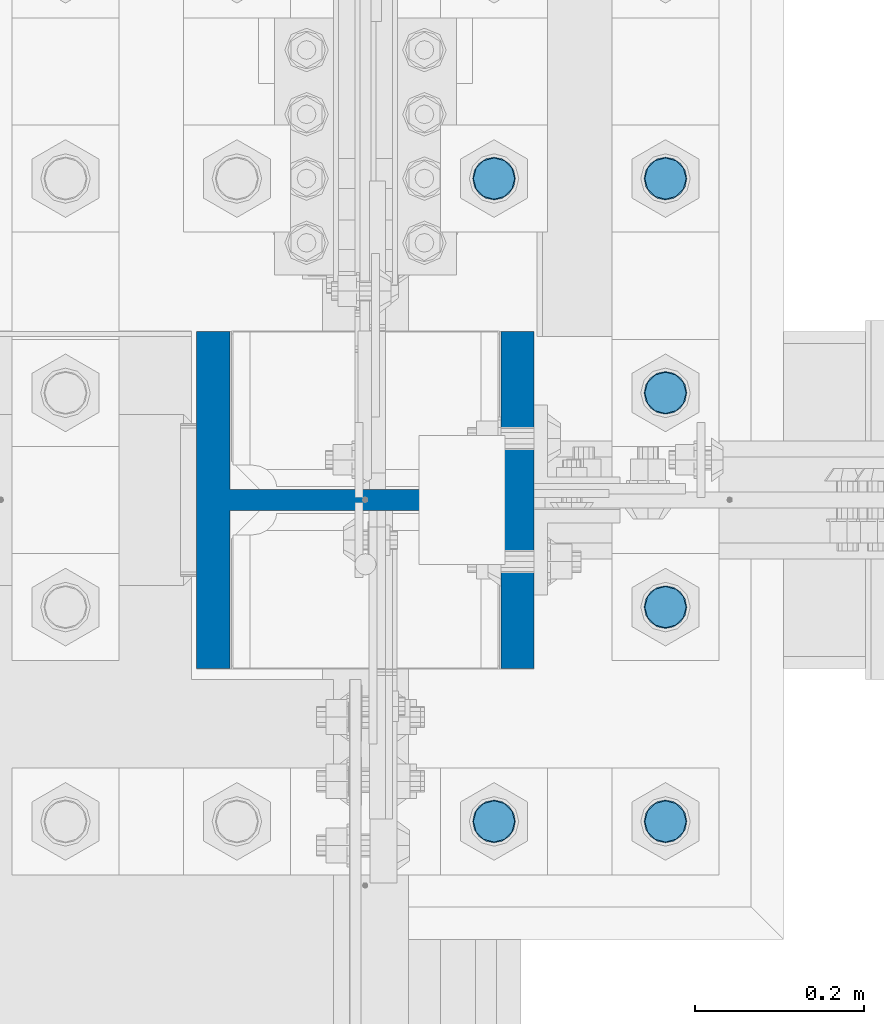
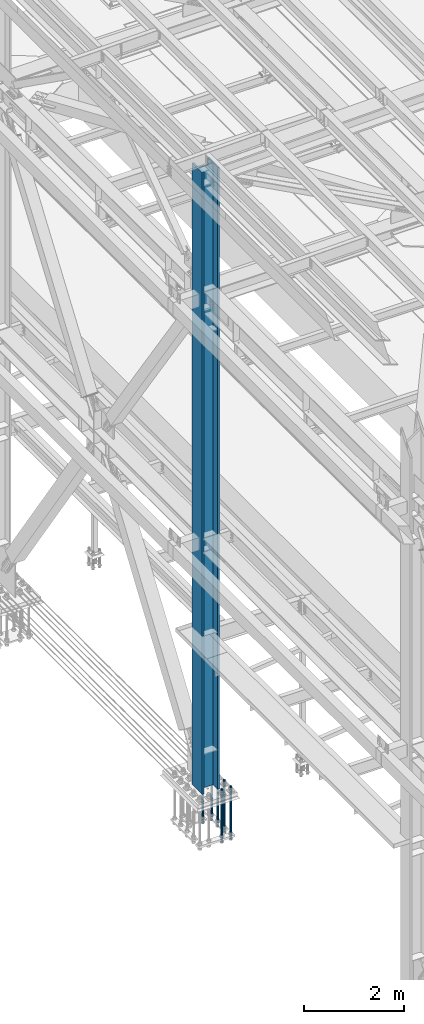
# One storey, part 1354 of 3843: 7 columns, 2 elements without a shape of their own.
"""IFC2X3 building model written with IfcOpenShell, lengths in millimetres."""

from ifc_helpers import new_model, si_unit, frame, origin_with_axes, place, context, subcontext, project, spatial, faceted_brep, material, type_object, element, aggregate, save


model = new_model("IFC2X3")

# Units and contexts
model_context = context("Model", 3, precision=1e-05, world=origin_with_axes())
body_context = subcontext(model_context, "Body", "Model", "MODEL_VIEW")
ifc_project = project(units=[si_unit("LENGTHUNIT", "METRE", prefix="MILLI"), si_unit("AREAUNIT", "SQUARE_METRE"), si_unit("VOLUMEUNIT", "CUBIC_METRE"), si_unit("MASSUNIT", "GRAM", prefix="KILO"), si_unit("TIMEUNIT", "SECOND"), si_unit("PLANEANGLEUNIT", "RADIAN"), si_unit("SOLIDANGLEUNIT", "STERADIAN"), si_unit("THERMODYNAMICTEMPERATUREUNIT", "DEGREE_CELSIUS"), si_unit("LUMINOUSINTENSITYUNIT", "LUMEN")], contexts=[model_context])

# Site, building, storey
site_placement = place(None, origin_with_axes())
site = spatial("IfcSite", under=ifc_project, at=site_placement, CompositionType="ELEMENT")
building_placement = place(site_placement, origin_with_axes())
building = spatial("IfcBuilding", under=site, at=building_placement, Name="Undefined", CompositionType="ELEMENT")
storey_placement = place(building_placement, origin_with_axes())
storey = spatial("IfcBuildingStorey", under=building, at=storey_placement, Name="Undefined", CompositionType="ELEMENT", Elevation=0.0)

# Assembly, columns
assembly_1_placement = place(storey_placement, origin_with_axes())
assembly_1 = element("IfcElementAssembly", 1, at=assembly_1_placement, inside=storey, Name="TEMPLATE", AssemblyPlace="NOTDEFINED", PredefinedType="RIGID_FRAME")
ifc_material_1 = material(Name="Undefined/F1554-GR.55")
column_type_1 = type_object("IfcColumnType", PredefinedType="NOTDEFINED")
column_1_placement = place(assembly_1_placement, frame((36931.6, 66890.9, 30022.8), z_axis=(1.0, 0.0, 0.0), x_axis=(0.0, 0.0, -1.0)))
column_1 = element("IfcColumn", 2, at=column_1_placement, type_object=column_type_1, material=ifc_material_1, Name="ANCHOR_ROD", context=body_context, shape_type="Brep", body=[
    faceted_brep([(-266.700000000001, -21.2176223927236, 12.25), (-266.700000000001, -12.25, 21.2176223927163), (-266.700000000001, 0.0, 24.5), (-266.700000000001, 12.25, 21.2176223927163), (-266.700000000001, 21.2176223927236, 12.25), (-266.700000000001, 24.5, 0.0), (-266.700000000001, 21.2176223927236, -12.25), (-266.700000000001, 12.25, -21.2176223927163), (-266.700000000001, 0.0, -24.5), (-266.700000000001, -12.25, -21.2176223927163), (-266.700000000001, -21.2176223927236, -12.25), (-266.700000000001, -24.5, 0.0), (0.0, 24.5000000000146, 0.0), (0.0, 21.2176223927381, -12.25), (0.0, 12.2500000000146, -21.2176223927163), (0.0, 1.45519152283669e-11, -24.5), (0.0, -12.2499999999854, -21.2176223927163), (0.0, -21.217622392709, -12.25), (0.0, -24.4999999999854, 0.0), (0.0, -21.217622392709, 12.25), (0.0, -12.2499999999854, 21.2176223927163), (0.0, 1.45519152283669e-11, 24.5), (0.0, 12.2500000000146, 21.2176223927163), (0.0, 21.2176223927381, 12.25), (0.0, -23.4665401257807, 9.72015918207035), (0.0, -17.9605122421344, 17.9605122421417), (0.0, -9.72015918207762, 23.466540125788), (0.0, 0.0, 25.4000000000015), (0.0, 9.72015918207762, 23.466540125788), (0.0, 17.9605122421344, 17.9605122421417), (0.0, 23.4665401257807, 9.72015918207035), (0.0, 25.3999996185303, 0.0), (0.0, 23.4665401257807, -9.72015918207035), (0.0, 17.9605122421344, -17.9605122421417), (0.0, 9.72015918207762, -23.466540125788), (0.0, 0.0, -25.4000000000015), (0.0, -9.72015918207762, -23.466540125788), (0.0, -17.9605122421344, -17.9605122421417), (0.0, -23.4665401257807, -9.72015918207035), (0.0, -25.3999996185303, 0.0), (812.799999999999, -25.4000000000015, 0.0), (812.799999999999, -23.466540125788, 9.72015918207398), (812.799999999999, -17.9605122421417, 17.9605122421381), (812.799999999999, -9.72015918207035, 23.466540125788), (812.799999999999, 0.0, 25.4000000000015), (812.799999999999, 9.72015918207035, 23.466540125788), (812.799999999999, 17.9605122421417, 17.9605122421381), (812.799999999999, 23.466540125788, 9.72015918207398), (812.799999999999, 25.4000000000015, 0.0), (812.799999999999, 23.466540125788, -9.72015918207398), (812.799999999999, 17.9605122421417, -17.9605122421381), (812.799999999999, 9.72015918207035, -23.466540125788), (812.799999999999, 0.0, -25.4000000000015), (812.799999999999, -9.72015918207035, -23.466540125788), (812.799999999999, -17.9605122421417, -17.9605122421381), (812.799999999999, -23.466540125788, -9.72015918207398), (812.799999999999, -12.25, 21.2176223927199), (812.799999999999, 0.0, 24.5), (812.799999999999, 12.25, 21.2176223927199), (812.799999999999, 21.2176223927163, 12.25), (812.799999999999, 24.5, 0.0), (812.799999999999, 21.2176223927163, -12.25), (812.799999999999, 12.25, -21.2176223927199), (812.799999999999, 0.0, -24.5), (812.799999999999, -12.25, -21.2176223927199), (812.799999999999, -21.2176223927163, -12.25), (812.799999999999, -24.5, 0.0), (812.799999999999, -21.2176223927163, 12.25), (1041.4, -12.25, -21.2176223927199), (1041.4, 0.0, -24.5), (1041.4, 12.25, -21.2176223927199), (1041.4, 21.2176223927163, -12.25), (1041.4, 24.5, 0.0), (1041.4, 21.2176223927163, 12.25), (1041.4, 12.25, 21.2176223927199), (1041.4, 0.0, 24.5), (1041.4, -12.25, 21.2176223927199), (1041.4, -21.2176223927163, 12.25), (1041.4, -24.5, 0.0), (1041.4, -21.2176223927163, -12.25)], [[[0, 1, 2, 3, 4, 5, 6, 7, 8, 9, 10, 11]], [[6, 5, 12, 13]], [[7, 6, 13, 14]], [[8, 7, 14, 15]], [[9, 8, 15, 16]], [[10, 9, 16, 17]], [[11, 10, 17, 18]], [[0, 11, 18, 19]], [[1, 0, 19, 20]], [[2, 1, 20, 21]], [[3, 2, 21, 22]], [[4, 3, 22, 23]], [[5, 4, 23, 12]], [[24, 25, 26, 27, 28, 29, 30, 31, 32, 33, 34, 35, 36, 37, 38, 39], [22, 21, 20, 19, 18, 17, 16, 15, 14, 13, 12, 23]], [[24, 39, 40, 41]], [[25, 24, 41, 42]], [[26, 25, 42, 43]], [[27, 26, 43, 44]], [[28, 27, 44, 45]], [[29, 28, 45, 46]], [[30, 29, 46, 47]], [[31, 30, 47, 48]], [[32, 31, 48, 49]], [[33, 32, 49, 50]], [[34, 33, 50, 51]], [[35, 34, 51, 52]], [[36, 35, 52, 53]], [[37, 36, 53, 54]], [[38, 37, 54, 55]], [[39, 38, 55, 40]], [[54, 53, 52, 51, 50, 49, 48, 47, 46, 45, 44, 43, 42, 41, 40, 55], [56, 57, 58, 59, 60, 61, 62, 63, 64, 65, 66, 67]], [[68, 69, 70, 71, 72, 73, 74, 75, 76, 77, 78, 79]], [[76, 75, 57, 56]], [[77, 76, 56, 67]], [[78, 77, 67, 66]], [[79, 78, 66, 65]], [[68, 79, 65, 64]], [[69, 68, 64, 63]], [[70, 69, 63, 62]], [[71, 70, 62, 61]], [[72, 71, 61, 60]], [[73, 72, 60, 59]], [[74, 73, 59, 58]], [[75, 74, 58, 57]]]),
])
column_2_placement = place(assembly_1_placement, frame((36931.6, 67144.9, 30022.8), z_axis=(1.0, 0.0, 0.0), x_axis=(0.0, 0.0, -1.0)))
column_2 = element("IfcColumn", 3, at=column_2_placement, type_object=column_type_1, material=ifc_material_1, Name="ANCHOR_ROD", context=body_context, shape_type="Brep", body=[
    faceted_brep([(-266.700000000001, -21.2176223927236, 12.25), (-266.700000000001, -12.25, 21.2176223927163), (-266.700000000001, 0.0, 24.5), (-266.700000000001, 12.25, 21.2176223927163), (-266.700000000001, 21.2176223927236, 12.25), (-266.700000000001, 24.5, 0.0), (-266.700000000001, 21.2176223927236, -12.25), (-266.700000000001, 12.25, -21.2176223927163), (-266.700000000001, 0.0, -24.5), (-266.700000000001, -12.25, -21.2176223927163), (-266.700000000001, -21.2176223927236, -12.25), (-266.700000000001, -24.5, 0.0), (0.0, 24.5000000000146, 0.0), (0.0, 21.2176223927381, -12.25), (0.0, 12.2500000000146, -21.2176223927163), (0.0, 1.45519152283669e-11, -24.5), (0.0, -12.2499999999854, -21.2176223927163), (0.0, -21.217622392709, -12.25), (0.0, -24.4999999999854, 0.0), (0.0, -21.217622392709, 12.25), (0.0, -12.2499999999854, 21.2176223927163), (0.0, 1.45519152283669e-11, 24.5), (0.0, 12.2500000000146, 21.2176223927163), (0.0, 21.2176223927381, 12.25), (0.0, -23.4665401257807, 9.72015918207035), (0.0, -17.9605122421344, 17.9605122421417), (0.0, -9.72015918207762, 23.466540125788), (0.0, 0.0, 25.4000000000015), (0.0, 9.72015918207762, 23.466540125788), (0.0, 17.9605122421344, 17.9605122421417), (0.0, 23.4665401257807, 9.72015918207035), (0.0, 25.3999996185303, 0.0), (0.0, 23.4665401257807, -9.72015918207035), (0.0, 17.9605122421344, -17.9605122421417), (0.0, 9.72015918207762, -23.466540125788), (0.0, 0.0, -25.4000000000015), (0.0, -9.72015918207762, -23.466540125788), (0.0, -17.9605122421344, -17.9605122421417), (0.0, -23.4665401257807, -9.72015918207035), (0.0, -25.3999996185303, 0.0), (812.799999999999, -25.4000000000015, 0.0), (812.799999999999, -23.466540125788, 9.72015918207398), (812.799999999999, -17.9605122421417, 17.9605122421381), (812.799999999999, -9.72015918207035, 23.466540125788), (812.799999999999, 0.0, 25.4000000000015), (812.799999999999, 9.72015918207035, 23.466540125788), (812.799999999999, 17.9605122421417, 17.9605122421381), (812.799999999999, 23.466540125788, 9.72015918207398), (812.799999999999, 25.4000000000015, 0.0), (812.799999999999, 23.466540125788, -9.72015918207398), (812.799999999999, 17.9605122421417, -17.9605122421381), (812.799999999999, 9.72015918207035, -23.466540125788), (812.799999999999, 0.0, -25.4000000000015), (812.799999999999, -9.72015918207035, -23.466540125788), (812.799999999999, -17.9605122421417, -17.9605122421381), (812.799999999999, -23.466540125788, -9.72015918207398), (812.799999999999, -12.25, 21.2176223927199), (812.799999999999, 0.0, 24.5), (812.799999999999, 12.25, 21.2176223927199), (812.799999999999, 21.2176223927163, 12.25), (812.799999999999, 24.5, 0.0), (812.799999999999, 21.2176223927163, -12.25), (812.799999999999, 12.25, -21.2176223927199), (812.799999999999, 0.0, -24.5), (812.799999999999, -12.25, -21.2176223927199), (812.799999999999, -21.2176223927163, -12.25), (812.799999999999, -24.5, 0.0), (812.799999999999, -21.2176223927163, 12.25), (1041.4, -12.25, -21.2176223927199), (1041.4, 0.0, -24.5), (1041.4, 12.25, -21.2176223927199), (1041.4, 21.2176223927163, -12.25), (1041.4, 24.5, 0.0), (1041.4, 21.2176223927163, 12.25), (1041.4, 12.25, 21.2176223927199), (1041.4, 0.0, 24.5), (1041.4, -12.25, 21.2176223927199), (1041.4, -21.2176223927163, 12.25), (1041.4, -24.5, 0.0), (1041.4, -21.2176223927163, -12.25)], [[[0, 1, 2, 3, 4, 5, 6, 7, 8, 9, 10, 11]], [[6, 5, 12, 13]], [[7, 6, 13, 14]], [[8, 7, 14, 15]], [[9, 8, 15, 16]], [[10, 9, 16, 17]], [[11, 10, 17, 18]], [[0, 11, 18, 19]], [[1, 0, 19, 20]], [[2, 1, 20, 21]], [[3, 2, 21, 22]], [[4, 3, 22, 23]], [[5, 4, 23, 12]], [[24, 25, 26, 27, 28, 29, 30, 31, 32, 33, 34, 35, 36, 37, 38, 39], [22, 21, 20, 19, 18, 17, 16, 15, 14, 13, 12, 23]], [[24, 39, 40, 41]], [[25, 24, 41, 42]], [[26, 25, 42, 43]], [[27, 26, 43, 44]], [[28, 27, 44, 45]], [[29, 28, 45, 46]], [[30, 29, 46, 47]], [[31, 30, 47, 48]], [[32, 31, 48, 49]], [[33, 32, 49, 50]], [[34, 33, 50, 51]], [[35, 34, 51, 52]], [[36, 35, 52, 53]], [[37, 36, 53, 54]], [[38, 37, 54, 55]], [[39, 38, 55, 40]], [[54, 53, 52, 51, 50, 49, 48, 47, 46, 45, 44, 43, 42, 41, 40, 55], [56, 57, 58, 59, 60, 61, 62, 63, 64, 65, 66, 67]], [[68, 69, 70, 71, 72, 73, 74, 75, 76, 77, 78, 79]], [[76, 75, 57, 56]], [[77, 76, 56, 67]], [[78, 77, 67, 66]], [[79, 78, 66, 65]], [[68, 79, 65, 64]], [[69, 68, 64, 63]], [[70, 69, 63, 62]], [[71, 70, 62, 61]], [[72, 71, 61, 60]], [[73, 72, 60, 59]], [[74, 73, 59, 58]], [[75, 74, 58, 57]]]),
])
column_3_placement = place(assembly_1_placement, frame((36931.6, 67398.9, 30022.8), z_axis=(1.0, 0.0, 0.0), x_axis=(0.0, 0.0, -1.0)))
column_3 = element("IfcColumn", 4, at=column_3_placement, type_object=column_type_1, material=ifc_material_1, Name="ANCHOR_ROD", context=body_context, shape_type="Brep", body=[
    faceted_brep([(-266.700000000001, -21.2176223927236, 12.25), (-266.700000000001, -12.25, 21.2176223927163), (-266.700000000001, 0.0, 24.5), (-266.700000000001, 12.25, 21.2176223927163), (-266.700000000001, 21.2176223927236, 12.25), (-266.700000000001, 24.5, 0.0), (-266.700000000001, 21.2176223927236, -12.25), (-266.700000000001, 12.25, -21.2176223927163), (-266.700000000001, 0.0, -24.5), (-266.700000000001, -12.25, -21.2176223927163), (-266.700000000001, -21.2176223927236, -12.25), (-266.700000000001, -24.5, 0.0), (0.0, 24.5000000000146, 0.0), (0.0, 21.2176223927381, -12.25), (0.0, 12.2500000000146, -21.2176223927163), (0.0, 1.45519152283669e-11, -24.5), (0.0, -12.2499999999854, -21.2176223927163), (0.0, -21.217622392709, -12.25), (0.0, -24.4999999999854, 0.0), (0.0, -21.217622392709, 12.25), (0.0, -12.2499999999854, 21.2176223927163), (0.0, 1.45519152283669e-11, 24.5), (0.0, 12.2500000000146, 21.2176223927163), (0.0, 21.2176223927381, 12.25), (0.0, -23.4665401257807, 9.72015918207035), (0.0, -17.9605122421344, 17.9605122421417), (0.0, -9.72015918207762, 23.466540125788), (0.0, 0.0, 25.4000000000015), (0.0, 9.72015918207762, 23.466540125788), (0.0, 17.9605122421344, 17.9605122421417), (0.0, 23.4665401257807, 9.72015918207035), (0.0, 25.3999996185303, 0.0), (0.0, 23.4665401257807, -9.72015918207035), (0.0, 17.9605122421344, -17.9605122421417), (0.0, 9.72015918207762, -23.466540125788), (0.0, 0.0, -25.4000000000015), (0.0, -9.72015918207762, -23.466540125788), (0.0, -17.9605122421344, -17.9605122421417), (0.0, -23.4665401257807, -9.72015918207035), (0.0, -25.3999996185303, 0.0), (812.799999999999, -25.4000000000015, 0.0), (812.799999999999, -23.466540125788, 9.72015918207398), (812.799999999999, -17.9605122421417, 17.9605122421381), (812.799999999999, -9.72015918207035, 23.466540125788), (812.799999999999, 0.0, 25.4000000000015), (812.799999999999, 9.72015918207035, 23.466540125788), (812.799999999999, 17.9605122421417, 17.9605122421381), (812.799999999999, 23.466540125788, 9.72015918207398), (812.799999999999, 25.4000000000015, 0.0), (812.799999999999, 23.466540125788, -9.72015918207398), (812.799999999999, 17.9605122421417, -17.9605122421381), (812.799999999999, 9.72015918207035, -23.466540125788), (812.799999999999, 0.0, -25.4000000000015), (812.799999999999, -9.72015918207035, -23.466540125788), (812.799999999999, -17.9605122421417, -17.9605122421381), (812.799999999999, -23.466540125788, -9.72015918207398), (812.799999999999, -12.25, 21.2176223927199), (812.799999999999, 0.0, 24.5), (812.799999999999, 12.25, 21.2176223927199), (812.799999999999, 21.2176223927163, 12.25), (812.799999999999, 24.5, 0.0), (812.799999999999, 21.2176223927163, -12.25), (812.799999999999, 12.25, -21.2176223927199), (812.799999999999, 0.0, -24.5), (812.799999999999, -12.25, -21.2176223927199), (812.799999999999, -21.2176223927163, -12.25), (812.799999999999, -24.5, 0.0), (812.799999999999, -21.2176223927163, 12.25), (1041.4, -12.25, -21.2176223927199), (1041.4, 0.0, -24.5), (1041.4, 12.25, -21.2176223927199), (1041.4, 21.2176223927163, -12.25), (1041.4, 24.5, 0.0), (1041.4, 21.2176223927163, 12.25), (1041.4, 12.25, 21.2176223927199), (1041.4, 0.0, 24.5), (1041.4, -12.25, 21.2176223927199), (1041.4, -21.2176223927163, 12.25), (1041.4, -24.5, 0.0), (1041.4, -21.2176223927163, -12.25)], [[[0, 1, 2, 3, 4, 5, 6, 7, 8, 9, 10, 11]], [[6, 5, 12, 13]], [[7, 6, 13, 14]], [[8, 7, 14, 15]], [[9, 8, 15, 16]], [[10, 9, 16, 17]], [[11, 10, 17, 18]], [[0, 11, 18, 19]], [[1, 0, 19, 20]], [[2, 1, 20, 21]], [[3, 2, 21, 22]], [[4, 3, 22, 23]], [[5, 4, 23, 12]], [[24, 25, 26, 27, 28, 29, 30, 31, 32, 33, 34, 35, 36, 37, 38, 39], [22, 21, 20, 19, 18, 17, 16, 15, 14, 13, 12, 23]], [[24, 39, 40, 41]], [[25, 24, 41, 42]], [[26, 25, 42, 43]], [[27, 26, 43, 44]], [[28, 27, 44, 45]], [[29, 28, 45, 46]], [[30, 29, 46, 47]], [[31, 30, 47, 48]], [[32, 31, 48, 49]], [[33, 32, 49, 50]], [[34, 33, 50, 51]], [[35, 34, 51, 52]], [[36, 35, 52, 53]], [[37, 36, 53, 54]], [[38, 37, 54, 55]], [[39, 38, 55, 40]], [[54, 53, 52, 51, 50, 49, 48, 47, 46, 45, 44, 43, 42, 41, 40, 55], [56, 57, 58, 59, 60, 61, 62, 63, 64, 65, 66, 67]], [[68, 69, 70, 71, 72, 73, 74, 75, 76, 77, 78, 79]], [[76, 75, 57, 56]], [[77, 76, 56, 67]], [[78, 77, 67, 66]], [[79, 78, 66, 65]], [[68, 79, 65, 64]], [[69, 68, 64, 63]], [[70, 69, 63, 62]], [[71, 70, 62, 61]], [[72, 71, 61, 60]], [[73, 72, 60, 59]], [[74, 73, 59, 58]], [[75, 74, 58, 57]]]),
])
column_4_placement = place(assembly_1_placement, frame((36931.6, 67652.9, 30022.8), z_axis=(-1.0, 0.0, 0.0), x_axis=(0.0, 0.0, -1.0)))
column_4 = element("IfcColumn", 5, at=column_4_placement, type_object=column_type_1, material=ifc_material_1, Name="ANCHOR_ROD", context=body_context, shape_type="Brep", body=[
    faceted_brep([(-266.700000000001, -21.2176223927236, 12.25), (-266.700000000001, -12.25, 21.2176223927163), (-266.700000000001, 0.0, 24.5), (-266.700000000001, 12.25, 21.2176223927163), (-266.700000000001, 21.2176223927236, 12.25), (-266.700000000001, 24.5, 0.0), (-266.700000000001, 21.2176223927236, -12.25), (-266.700000000001, 12.25, -21.2176223927163), (-266.700000000001, 0.0, -24.5), (-266.700000000001, -12.25, -21.2176223927163), (-266.700000000001, -21.2176223927236, -12.25), (-266.700000000001, -24.5, 0.0), (0.0, 24.5000000000146, 0.0), (0.0, 21.2176223927381, -12.25), (0.0, 12.2500000000146, -21.2176223927163), (0.0, 1.45519152283669e-11, -24.5), (0.0, -12.2499999999854, -21.2176223927163), (0.0, -21.217622392709, -12.25), (0.0, -24.4999999999854, 0.0), (0.0, -21.217622392709, 12.25), (0.0, -12.2499999999854, 21.2176223927163), (0.0, 1.45519152283669e-11, 24.5), (0.0, 12.2500000000146, 21.2176223927163), (0.0, 21.2176223927381, 12.25), (0.0, -23.4665401257807, 9.72015918207035), (0.0, -17.9605122421344, 17.9605122421417), (0.0, -9.72015918207762, 23.466540125788), (0.0, 0.0, 25.4000000000015), (0.0, 9.72015918207762, 23.466540125788), (0.0, 17.9605122421344, 17.9605122421417), (0.0, 23.4665401257807, 9.72015918207035), (0.0, 25.3999996185303, 0.0), (0.0, 23.4665401257807, -9.72015918207035), (0.0, 17.9605122421344, -17.9605122421417), (0.0, 9.72015918207762, -23.466540125788), (0.0, 0.0, -25.4000000000015), (0.0, -9.72015918207762, -23.466540125788), (0.0, -17.9605122421344, -17.9605122421417), (0.0, -23.4665401257807, -9.72015918207035), (0.0, -25.3999996185303, 0.0), (812.799999999999, -25.4000000000015, 0.0), (812.799999999999, -23.466540125788, 9.72015918207398), (812.799999999999, -17.9605122421417, 17.9605122421381), (812.799999999999, -9.72015918207035, 23.466540125788), (812.799999999999, 0.0, 25.4000000000015), (812.799999999999, 9.72015918207035, 23.466540125788), (812.799999999999, 17.9605122421417, 17.9605122421381), (812.799999999999, 23.466540125788, 9.72015918207398), (812.799999999999, 25.4000000000015, 0.0), (812.799999999999, 23.466540125788, -9.72015918207398), (812.799999999999, 17.9605122421417, -17.9605122421381), (812.799999999999, 9.72015918207035, -23.466540125788), (812.799999999999, 0.0, -25.4000000000015), (812.799999999999, -9.72015918207035, -23.466540125788), (812.799999999999, -17.9605122421417, -17.9605122421381), (812.799999999999, -23.466540125788, -9.72015918207398), (812.799999999999, -12.25, 21.2176223927199), (812.799999999999, 0.0, 24.5), (812.799999999999, 12.25, 21.2176223927199), (812.799999999999, 21.2176223927163, 12.25), (812.799999999999, 24.5, 0.0), (812.799999999999, 21.2176223927163, -12.25), (812.799999999999, 12.25, -21.2176223927199), (812.799999999999, 0.0, -24.5), (812.799999999999, -12.25, -21.2176223927199), (812.799999999999, -21.2176223927163, -12.25), (812.799999999999, -24.5, 0.0), (812.799999999999, -21.2176223927163, 12.25), (1041.4, -12.25, -21.2176223927199), (1041.4, 0.0, -24.5), (1041.4, 12.25, -21.2176223927199), (1041.4, 21.2176223927163, -12.25), (1041.4, 24.5, 0.0), (1041.4, 21.2176223927163, 12.25), (1041.4, 12.25, 21.2176223927199), (1041.4, 0.0, 24.5), (1041.4, -12.25, 21.2176223927199), (1041.4, -21.2176223927163, 12.25), (1041.4, -24.5, 0.0), (1041.4, -21.2176223927163, -12.25)], [[[0, 1, 2, 3, 4, 5, 6, 7, 8, 9, 10, 11]], [[6, 5, 12, 13]], [[7, 6, 13, 14]], [[8, 7, 14, 15]], [[9, 8, 15, 16]], [[10, 9, 16, 17]], [[11, 10, 17, 18]], [[0, 11, 18, 19]], [[1, 0, 19, 20]], [[2, 1, 20, 21]], [[3, 2, 21, 22]], [[4, 3, 22, 23]], [[5, 4, 23, 12]], [[24, 25, 26, 27, 28, 29, 30, 31, 32, 33, 34, 35, 36, 37, 38, 39], [22, 21, 20, 19, 18, 17, 16, 15, 14, 13, 12, 23]], [[24, 39, 40, 41]], [[25, 24, 41, 42]], [[26, 25, 42, 43]], [[27, 26, 43, 44]], [[28, 27, 44, 45]], [[29, 28, 45, 46]], [[30, 29, 46, 47]], [[31, 30, 47, 48]], [[32, 31, 48, 49]], [[33, 32, 49, 50]], [[34, 33, 50, 51]], [[35, 34, 51, 52]], [[36, 35, 52, 53]], [[37, 36, 53, 54]], [[38, 37, 54, 55]], [[39, 38, 55, 40]], [[54, 53, 52, 51, 50, 49, 48, 47, 46, 45, 44, 43, 42, 41, 40, 55], [56, 57, 58, 59, 60, 61, 62, 63, 64, 65, 66, 67]], [[68, 69, 70, 71, 72, 73, 74, 75, 76, 77, 78, 79]], [[76, 75, 57, 56]], [[77, 76, 56, 67]], [[78, 77, 67, 66]], [[79, 78, 66, 65]], [[68, 79, 65, 64]], [[69, 68, 64, 63]], [[70, 69, 63, 62]], [[71, 70, 62, 61]], [[72, 71, 61, 60]], [[73, 72, 60, 59]], [[74, 73, 59, 58]], [[75, 74, 58, 57]]]),
])
column_5_placement = place(assembly_1_placement, frame((36728.4, 66890.9, 30022.8), z_axis=(1.0, 0.0, 0.0), x_axis=(0.0, 0.0, -1.0)))
column_5 = element("IfcColumn", 6, at=column_5_placement, type_object=column_type_1, material=ifc_material_1, Name="ANCHOR_ROD", context=body_context, shape_type="Brep", body=[
    faceted_brep([(-266.700000000001, -21.2176223927236, 12.25), (-266.700000000001, -12.25, 21.2176223927163), (-266.700000000001, 0.0, 24.5), (-266.700000000001, 12.25, 21.2176223927163), (-266.700000000001, 21.2176223927236, 12.25), (-266.700000000001, 24.5, 0.0), (-266.700000000001, 21.2176223927236, -12.25), (-266.700000000001, 12.25, -21.2176223927163), (-266.700000000001, 0.0, -24.5), (-266.700000000001, -12.25, -21.2176223927163), (-266.700000000001, -21.2176223927236, -12.25), (-266.700000000001, -24.5, 0.0), (0.0, 24.5000000000146, 0.0), (0.0, 21.2176223927381, -12.25), (0.0, 12.2500000000146, -21.2176223927163), (0.0, 1.45519152283669e-11, -24.5), (0.0, -12.2499999999854, -21.2176223927163), (0.0, -21.217622392709, -12.25), (0.0, -24.4999999999854, 0.0), (0.0, -21.217622392709, 12.25), (0.0, -12.2499999999854, 21.2176223927163), (0.0, 1.45519152283669e-11, 24.5), (0.0, 12.2500000000146, 21.2176223927163), (0.0, 21.2176223927381, 12.25), (0.0, -23.4665401257807, 9.72015918207035), (0.0, -17.9605122421344, 17.9605122421417), (0.0, -9.72015918207762, 23.466540125788), (0.0, 0.0, 25.4000000000015), (0.0, 9.72015918207762, 23.466540125788), (0.0, 17.9605122421344, 17.9605122421417), (0.0, 23.4665401257807, 9.72015918207035), (0.0, 25.3999996185303, 0.0), (0.0, 23.4665401257807, -9.72015918207035), (0.0, 17.9605122421344, -17.9605122421417), (0.0, 9.72015918207762, -23.466540125788), (0.0, 0.0, -25.4000000000015), (0.0, -9.72015918207762, -23.466540125788), (0.0, -17.9605122421344, -17.9605122421417), (0.0, -23.4665401257807, -9.72015918207035), (0.0, -25.3999996185303, 0.0), (812.799999999999, -25.4000000000015, 0.0), (812.799999999999, -23.466540125788, 9.72015918207398), (812.799999999999, -17.9605122421417, 17.9605122421381), (812.799999999999, -9.72015918207035, 23.466540125788), (812.799999999999, 0.0, 25.4000000000015), (812.799999999999, 9.72015918207035, 23.466540125788), (812.799999999999, 17.9605122421417, 17.9605122421381), (812.799999999999, 23.466540125788, 9.72015918207398), (812.799999999999, 25.4000000000015, 0.0), (812.799999999999, 23.466540125788, -9.72015918207398), (812.799999999999, 17.9605122421417, -17.9605122421381), (812.799999999999, 9.72015918207035, -23.466540125788), (812.799999999999, 0.0, -25.4000000000015), (812.799999999999, -9.72015918207035, -23.466540125788), (812.799999999999, -17.9605122421417, -17.9605122421381), (812.799999999999, -23.466540125788, -9.72015918207398), (812.799999999999, -12.25, 21.2176223927199), (812.799999999999, 0.0, 24.5), (812.799999999999, 12.25, 21.2176223927199), (812.799999999999, 21.2176223927163, 12.25), (812.799999999999, 24.5, 0.0), (812.799999999999, 21.2176223927163, -12.25), (812.799999999999, 12.25, -21.2176223927199), (812.799999999999, 0.0, -24.5), (812.799999999999, -12.25, -21.2176223927199), (812.799999999999, -21.2176223927163, -12.25), (812.799999999999, -24.5, 0.0), (812.799999999999, -21.2176223927163, 12.25), (1041.4, -12.25, -21.2176223927199), (1041.4, 0.0, -24.5), (1041.4, 12.25, -21.2176223927199), (1041.4, 21.2176223927163, -12.25), (1041.4, 24.5, 0.0), (1041.4, 21.2176223927163, 12.25), (1041.4, 12.25, 21.2176223927199), (1041.4, 0.0, 24.5), (1041.4, -12.25, 21.2176223927199), (1041.4, -21.2176223927163, 12.25), (1041.4, -24.5, 0.0), (1041.4, -21.2176223927163, -12.25)], [[[0, 1, 2, 3, 4, 5, 6, 7, 8, 9, 10, 11]], [[6, 5, 12, 13]], [[7, 6, 13, 14]], [[8, 7, 14, 15]], [[9, 8, 15, 16]], [[10, 9, 16, 17]], [[11, 10, 17, 18]], [[0, 11, 18, 19]], [[1, 0, 19, 20]], [[2, 1, 20, 21]], [[3, 2, 21, 22]], [[4, 3, 22, 23]], [[5, 4, 23, 12]], [[24, 25, 26, 27, 28, 29, 30, 31, 32, 33, 34, 35, 36, 37, 38, 39], [22, 21, 20, 19, 18, 17, 16, 15, 14, 13, 12, 23]], [[24, 39, 40, 41]], [[25, 24, 41, 42]], [[26, 25, 42, 43]], [[27, 26, 43, 44]], [[28, 27, 44, 45]], [[29, 28, 45, 46]], [[30, 29, 46, 47]], [[31, 30, 47, 48]], [[32, 31, 48, 49]], [[33, 32, 49, 50]], [[34, 33, 50, 51]], [[35, 34, 51, 52]], [[36, 35, 52, 53]], [[37, 36, 53, 54]], [[38, 37, 54, 55]], [[39, 38, 55, 40]], [[54, 53, 52, 51, 50, 49, 48, 47, 46, 45, 44, 43, 42, 41, 40, 55], [56, 57, 58, 59, 60, 61, 62, 63, 64, 65, 66, 67]], [[68, 69, 70, 71, 72, 73, 74, 75, 76, 77, 78, 79]], [[76, 75, 57, 56]], [[77, 76, 56, 67]], [[78, 77, 67, 66]], [[79, 78, 66, 65]], [[68, 79, 65, 64]], [[69, 68, 64, 63]], [[70, 69, 63, 62]], [[71, 70, 62, 61]], [[72, 71, 61, 60]], [[73, 72, 60, 59]], [[74, 73, 59, 58]], [[75, 74, 58, 57]]]),
])
column_6_placement = place(assembly_1_placement, frame((36728.4, 67652.9, 30022.8), z_axis=(-1.0, 0.0, 0.0), x_axis=(0.0, 0.0, -1.0)))
column_6 = element("IfcColumn", 7, at=column_6_placement, type_object=column_type_1, material=ifc_material_1, Name="ANCHOR_ROD", context=body_context, shape_type="Brep", body=[
    faceted_brep([(-266.700000000001, -21.2176223927236, 12.25), (-266.700000000001, -12.25, 21.2176223927163), (-266.700000000001, 0.0, 24.5), (-266.700000000001, 12.25, 21.2176223927163), (-266.700000000001, 21.2176223927236, 12.25), (-266.700000000001, 24.5, 0.0), (-266.700000000001, 21.2176223927236, -12.25), (-266.700000000001, 12.25, -21.2176223927163), (-266.700000000001, 0.0, -24.5), (-266.700000000001, -12.25, -21.2176223927163), (-266.700000000001, -21.2176223927236, -12.25), (-266.700000000001, -24.5, 0.0), (0.0, 24.5000000000146, 0.0), (0.0, 21.2176223927381, -12.25), (0.0, 12.2500000000146, -21.2176223927163), (0.0, 1.45519152283669e-11, -24.5), (0.0, -12.2499999999854, -21.2176223927163), (0.0, -21.217622392709, -12.25), (0.0, -24.4999999999854, 0.0), (0.0, -21.217622392709, 12.25), (0.0, -12.2499999999854, 21.2176223927163), (0.0, 1.45519152283669e-11, 24.5), (0.0, 12.2500000000146, 21.2176223927163), (0.0, 21.2176223927381, 12.25), (0.0, -23.4665401257807, 9.72015918207035), (0.0, -17.9605122421344, 17.9605122421417), (0.0, -9.72015918207762, 23.466540125788), (0.0, 0.0, 25.4000000000015), (0.0, 9.72015918207762, 23.466540125788), (0.0, 17.9605122421344, 17.9605122421417), (0.0, 23.4665401257807, 9.72015918207035), (0.0, 25.3999996185303, 0.0), (0.0, 23.4665401257807, -9.72015918207035), (0.0, 17.9605122421344, -17.9605122421417), (0.0, 9.72015918207762, -23.466540125788), (0.0, 0.0, -25.4000000000015), (0.0, -9.72015918207762, -23.466540125788), (0.0, -17.9605122421344, -17.9605122421417), (0.0, -23.4665401257807, -9.72015918207035), (0.0, -25.3999996185303, 0.0), (812.799999999999, -25.4000000000015, 0.0), (812.799999999999, -23.466540125788, 9.72015918207398), (812.799999999999, -17.9605122421417, 17.9605122421381), (812.799999999999, -9.72015918207035, 23.466540125788), (812.799999999999, 0.0, 25.4000000000015), (812.799999999999, 9.72015918207035, 23.466540125788), (812.799999999999, 17.9605122421417, 17.9605122421381), (812.799999999999, 23.466540125788, 9.72015918207398), (812.799999999999, 25.4000000000015, 0.0), (812.799999999999, 23.466540125788, -9.72015918207398), (812.799999999999, 17.9605122421417, -17.9605122421381), (812.799999999999, 9.72015918207035, -23.466540125788), (812.799999999999, 0.0, -25.4000000000015), (812.799999999999, -9.72015918207035, -23.466540125788), (812.799999999999, -17.9605122421417, -17.9605122421381), (812.799999999999, -23.466540125788, -9.72015918207398), (812.799999999999, -12.25, 21.2176223927199), (812.799999999999, 0.0, 24.5), (812.799999999999, 12.25, 21.2176223927199), (812.799999999999, 21.2176223927163, 12.25), (812.799999999999, 24.5, 0.0), (812.799999999999, 21.2176223927163, -12.25), (812.799999999999, 12.25, -21.2176223927199), (812.799999999999, 0.0, -24.5), (812.799999999999, -12.25, -21.2176223927199), (812.799999999999, -21.2176223927163, -12.25), (812.799999999999, -24.5, 0.0), (812.799999999999, -21.2176223927163, 12.25), (1041.4, -12.25, -21.2176223927199), (1041.4, 0.0, -24.5), (1041.4, 12.25, -21.2176223927199), (1041.4, 21.2176223927163, -12.25), (1041.4, 24.5, 0.0), (1041.4, 21.2176223927163, 12.25), (1041.4, 12.25, 21.2176223927199), (1041.4, 0.0, 24.5), (1041.4, -12.25, 21.2176223927199), (1041.4, -21.2176223927163, 12.25), (1041.4, -24.5, 0.0), (1041.4, -21.2176223927163, -12.25)], [[[0, 1, 2, 3, 4, 5, 6, 7, 8, 9, 10, 11]], [[6, 5, 12, 13]], [[7, 6, 13, 14]], [[8, 7, 14, 15]], [[9, 8, 15, 16]], [[10, 9, 16, 17]], [[11, 10, 17, 18]], [[0, 11, 18, 19]], [[1, 0, 19, 20]], [[2, 1, 20, 21]], [[3, 2, 21, 22]], [[4, 3, 22, 23]], [[5, 4, 23, 12]], [[24, 25, 26, 27, 28, 29, 30, 31, 32, 33, 34, 35, 36, 37, 38, 39], [22, 21, 20, 19, 18, 17, 16, 15, 14, 13, 12, 23]], [[24, 39, 40, 41]], [[25, 24, 41, 42]], [[26, 25, 42, 43]], [[27, 26, 43, 44]], [[28, 27, 44, 45]], [[29, 28, 45, 46]], [[30, 29, 46, 47]], [[31, 30, 47, 48]], [[32, 31, 48, 49]], [[33, 32, 49, 50]], [[34, 33, 50, 51]], [[35, 34, 51, 52]], [[36, 35, 52, 53]], [[37, 36, 53, 54]], [[38, 37, 54, 55]], [[39, 38, 55, 40]], [[54, 53, 52, 51, 50, 49, 48, 47, 46, 45, 44, 43, 42, 41, 40, 55], [56, 57, 58, 59, 60, 61, 62, 63, 64, 65, 66, 67]], [[68, 69, 70, 71, 72, 73, 74, 75, 76, 77, 78, 79]], [[76, 75, 57, 56]], [[77, 76, 56, 67]], [[78, 77, 67, 66]], [[79, 78, 66, 65]], [[68, 79, 65, 64]], [[69, 68, 64, 63]], [[70, 69, 63, 62]], [[71, 70, 62, 61]], [[72, 71, 61, 60]], [[73, 72, 60, 59]], [[74, 73, 59, 58]], [[75, 74, 58, 57]]]),
])
aggregate(assembly_1, [column_1, column_2, column_3, column_4, column_5, column_6])

# Assembly, column
assembly_2_placement = place(storey_placement, origin_with_axes())
assembly_2 = element("IfcElementAssembly", 8, at=assembly_2_placement, inside=storey, Name="COLUMN", AssemblyPlace="NOTDEFINED", PredefinedType="RIGID_FRAME")
ifc_material_2 = material(Name="STEEL/A992")
column_type_2 = type_object("IfcColumnType", Name="W14X211", PredefinedType="NOTDEFINED")
column_7_placement = place(assembly_2_placement, frame((36576.0, 67271.9, 30022.8), z_axis=(-1.0, 0.0, 0.0), x_axis=(0.0, 0.0, 1.0)))
column_7 = element("IfcColumn", 9, at=column_7_placement, type_object=column_type_2, material=ifc_material_2, Name="COLUMN", ObjectType="W14X211", context=body_context, shape_type="Brep", body=[
    faceted_brep([(139.700000000008, -200.025000000001, -200.025000000001), (139.700000000008, -200.025000000001, -160.337500000001), (139.700000000008, -12.6999999999971, -160.337500000001), (139.700000000008, -12.6999999999971, 160.337500000001), (139.700000000008, -200.025000000001, 160.337500000001), (139.700000000008, -200.025000000001, 200.025000000001), (139.700000000008, 200.025000000001, 200.025000000001), (139.700000000008, 200.025000000001, 160.337500000001), (139.700000000008, 12.6999999999971, 160.337500000001), (139.700000000008, 12.6999999999971, -160.337500000001), (139.700000000008, 200.025000000001, -160.337500000001), (139.700000000008, 200.025000000001, -200.025000000001), (15377.807458475, -200.025000000001, 200.025000000001), (15377.807458475, 200.025000000001, 200.025000000001), (15377.807458475, 200.025000000001, 160.337500000001), (15377.807458475, 12.6999999999971, 160.337500000001), (15377.807458475, 12.6999999999971, -160.337500000001), (15377.807458475, 200.025000000001, -160.337500000001), (15377.807458475, 200.025000000001, -200.025000000001), (15377.807458475, -200.025000000001, -200.025000000001), (15377.807458475, -200.025000000001, -160.337500000001), (15377.807458475, -12.6999999999971, -160.337500000001), (15377.807458475, -12.6999999999971, 160.337500000001), (15377.807458475, -200.025000000001, 160.337500000001)], [[[0, 1, 2, 3, 4, 5, 6, 7, 8, 9, 10, 11]], [[6, 5, 12, 13]], [[7, 6, 13, 14]], [[8, 7, 14, 15]], [[9, 8, 15, 16]], [[10, 9, 16, 17]], [[11, 10, 17, 18]], [[0, 11, 18, 19]], [[1, 0, 19, 20]], [[2, 1, 20, 21]], [[3, 2, 21, 22]], [[4, 3, 22, 23]], [[5, 4, 23, 12]], [[22, 21, 20, 19, 18, 17, 16, 15, 14, 13, 12, 23]]]),
])
aggregate(assembly_2, [column_7])

save(model, "model.ifc")
